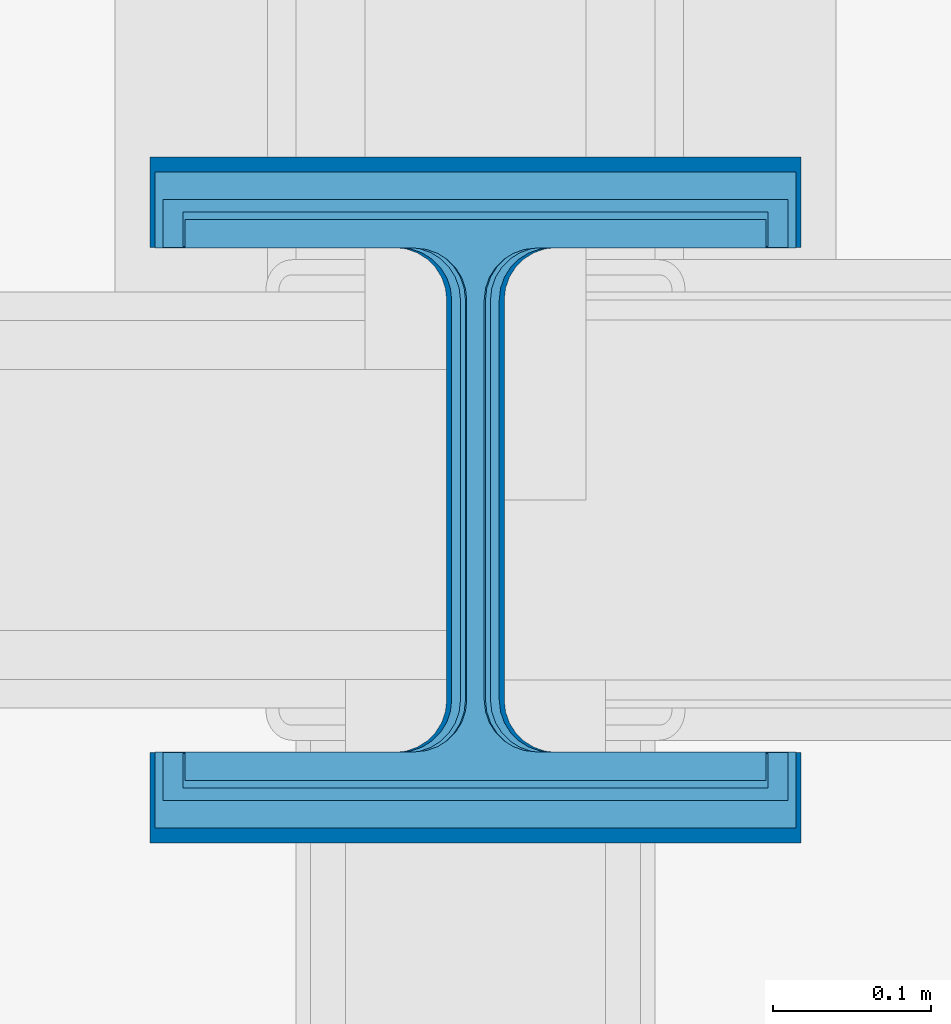
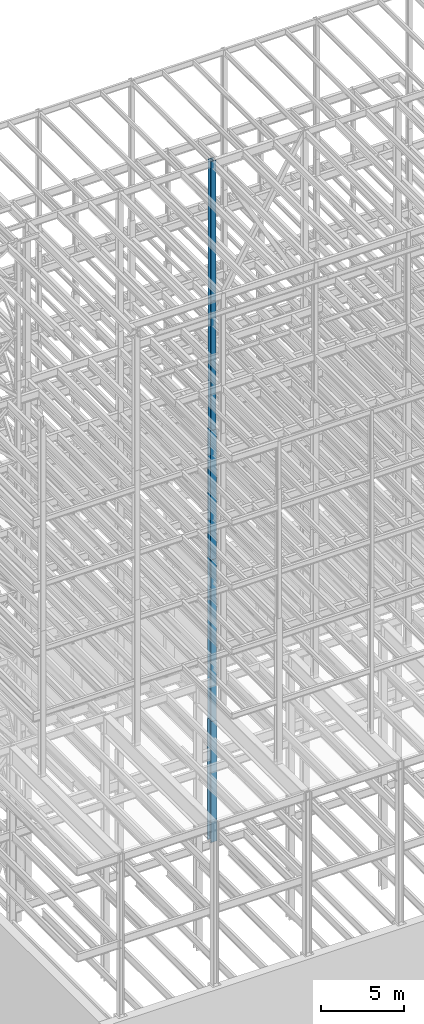
# One storey, part 19 of 150: 5 columns.
"""IFC2X3 building model written with IfcOpenShell, lengths in millimetres."""

from ifc_helpers import new_model, si_unit, frame, origin_with_axes, origin_2d_with_axis, place, context, subcontext, project, spatial, i_section, extrude, material, type_object, element, save


model = new_model("IFC2X3")

# Units and contexts
model_context = context("Model", 3, precision=1e-05, world=origin_with_axes())
body_context = subcontext(model_context, "Body", "Model", "MODEL_VIEW")
ifc_project = project(units=[si_unit("LENGTHUNIT", "METRE", prefix="MILLI"), si_unit("AREAUNIT", "SQUARE_METRE"), si_unit("VOLUMEUNIT", "CUBIC_METRE"), si_unit("MASSUNIT", "GRAM", prefix="KILO"), si_unit("TIMEUNIT", "SECOND"), si_unit("PLANEANGLEUNIT", "RADIAN"), si_unit("SOLIDANGLEUNIT", "STERADIAN"), si_unit("THERMODYNAMICTEMPERATUREUNIT", "DEGREE_CELSIUS"), si_unit("LUMINOUSINTENSITYUNIT", "LUMEN")], contexts=[model_context])

# Site, building, storey
site_placement = place(None, origin_with_axes())
site = spatial("IfcSite", under=ifc_project, at=site_placement, CompositionType="ELEMENT")
building_placement = place(site_placement, origin_with_axes())
building = spatial("IfcBuilding", under=site, at=building_placement, Name="Undefined", CompositionType="ELEMENT")
storey_placement = place(building_placement, origin_with_axes())
storey = spatial("IfcBuildingStorey", under=building, at=storey_placement, Name="Undefined", CompositionType="ELEMENT", Elevation=0.0)

# Columns
ifc_material = material(Name="STEEL/A992")
column_type_1 = type_object("IfcColumnType", Name="W14X311", PredefinedType="NOTDEFINED")
column_1_placement = place(storey_placement, frame((24587.2, 22479.0, 16154.4), z_axis=(0.0, 0.0, 1.0), x_axis=(1.0, 0.0, 0.0)))
element("IfcColumn", 1, at=column_1_placement, inside=storey, type_object=column_type_1, material=ifc_material, Name="COLUMN", ObjectType="W14X311", context=body_context, shape_type="SweptSolid", body=[
    extrude(i_section(OverallWidth=412.75, OverallDepth=434.975, WebThickness=36.5125, FlangeThickness=57.404, FilletRadius=33.0834, at=origin_2d_with_axis()), frame((0.0, 0.0, 8839.2), z_axis=(0.0, 0.0, -1.0), x_axis=(-1.0, 0.0, 0.0)), (0.0, 0.0, 1.0), 8839.2),
])
column_type_2 = type_object("IfcColumnType", Name="W14X90", PredefinedType="NOTDEFINED")
column_2_placement = place(storey_placement, frame((24587.2, 22479.0, 55702.2), z_axis=(0.0, 0.0, 1.0), x_axis=(1.0, 0.0, 0.0)))
element("IfcColumn", 2, at=column_2_placement, inside=storey, type_object=column_type_2, material=ifc_material, Name="COLUMN", ObjectType="W14X90", context=body_context, shape_type="SweptSolid", body=[
    extrude(i_section(OverallWidth=368.3, OverallDepth=355.6, WebThickness=11.1125, FlangeThickness=18.034, FilletRadius=32.7659, at=origin_2d_with_axis()), frame((0.0, 0.0, 10210.8), z_axis=(0.0, 0.0, -1.0), x_axis=(-1.0, 0.0, 0.0)), (0.0, 0.0, 1.0), 10210.8),
])
column_type_3 = type_object("IfcColumnType", Name="W14X257", PredefinedType="NOTDEFINED")
column_3_placement = place(storey_placement, frame((24587.2, 22479.0, 24993.6), z_axis=(0.0, 0.0, 1.0), x_axis=(1.0, 0.0, 0.0)))
element("IfcColumn", 3, at=column_3_placement, inside=storey, type_object=column_type_3, material=ifc_material, Name="COLUMN", ObjectType="W14X257", context=body_context, shape_type="SweptSolid", body=[
    extrude(i_section(OverallWidth=406.4, OverallDepth=415.925, WebThickness=30.1625, FlangeThickness=48.006, FilletRadius=32.9564, at=origin_2d_with_axis()), frame((0.0, 0.0, 11811.0), z_axis=(0.0, 0.0, -1.0), x_axis=(-1.0, 0.0, 0.0)), (0.0, 0.0, 1.0), 11811.0),
])
column_type_4 = type_object("IfcColumnType", Name="W14X109", PredefinedType="NOTDEFINED")
column_4_placement = place(storey_placement, frame((24587.2, 22479.0, 46253.4), z_axis=(0.0, 0.0, 1.0), x_axis=(1.0, 0.0, 0.0)))
element("IfcColumn", 4, at=column_4_placement, inside=storey, type_object=column_type_4, material=ifc_material, Name="COLUMN", ObjectType="W14X109", context=body_context, shape_type="SweptSolid", body=[
    extrude(i_section(OverallWidth=370.84, OverallDepth=365.125, WebThickness=12.6999, FlangeThickness=21.844, FilletRadius=33.7184, at=origin_2d_with_axis()), frame((0.0, 0.0, 9448.8), z_axis=(0.0, 0.0, -1.0), x_axis=(-1.0, 0.0, 0.0)), (0.0, 0.0, 1.0), 9448.8),
])
column_type_5 = type_object("IfcColumnType", Name="W14X159", PredefinedType="NOTDEFINED")
column_5_placement = place(storey_placement, frame((24587.2, 22479.0, 36804.6), z_axis=(0.0, 0.0, 1.0), x_axis=(1.0, 0.0, 0.0)))
element("IfcColumn", 5, at=column_5_placement, inside=storey, type_object=column_type_5, material=ifc_material, Name="COLUMN", ObjectType="W14X159", context=body_context, shape_type="SweptSolid", body=[
    extrude(i_section(OverallWidth=396.24, OverallDepth=381.0, WebThickness=19.0499, FlangeThickness=30.226, FilletRadius=33.2739, at=origin_2d_with_axis()), frame((0.0, 0.0, 9448.8), z_axis=(0.0, 0.0, -1.0), x_axis=(-1.0, 0.0, 0.0)), (0.0, 0.0, 1.0), 9448.8),
])

save(model, "model.ifc")
